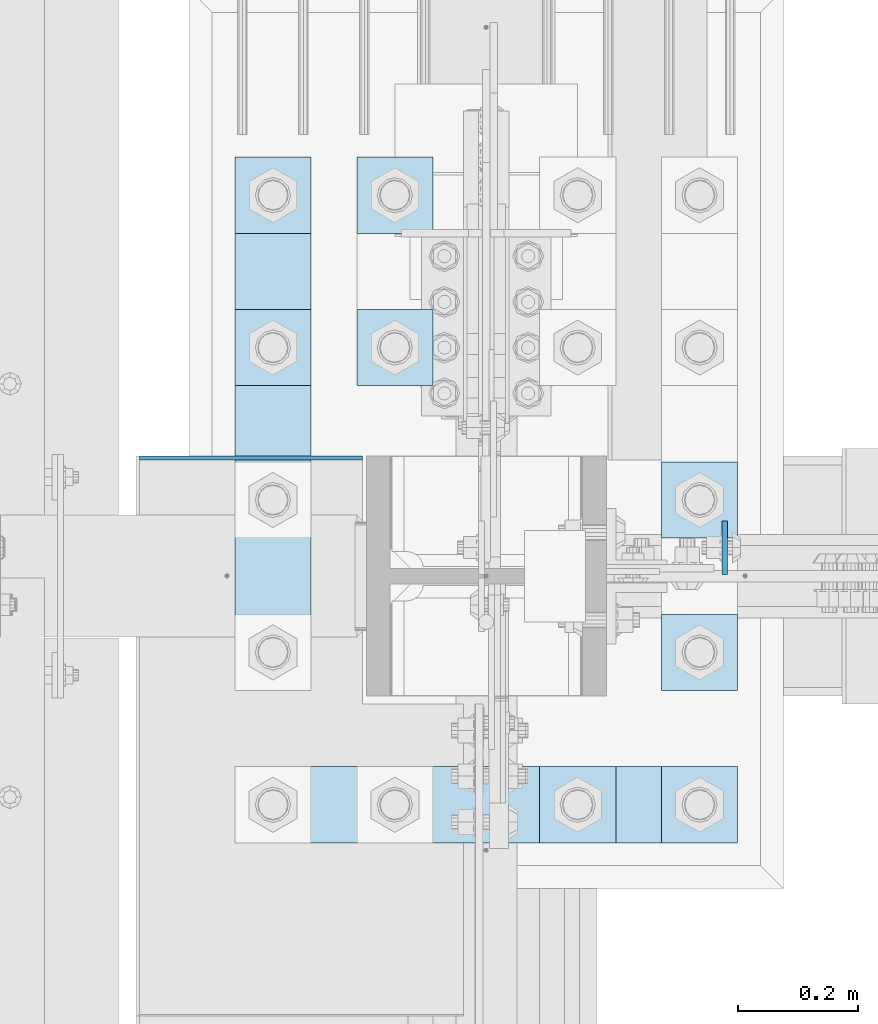
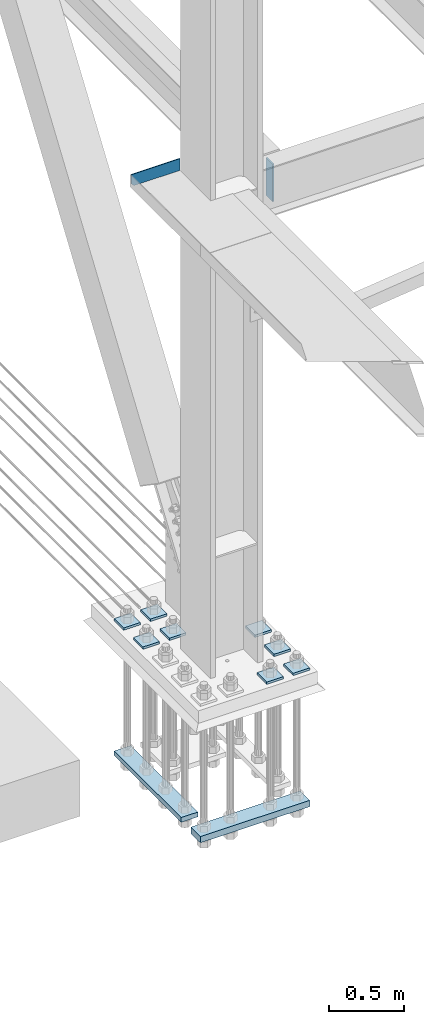
# One storey, part 3250 of 3843: 12 plates, 3 elements without a shape of their own.
"""IFC2X3 building model written with IfcOpenShell, lengths in millimetres."""

from ifc_helpers import new_model, si_unit, frame, origin_with_axes, place, context, subcontext, project, spatial, faceted_brep, material, type_object, element, aggregate, save


model = new_model("IFC2X3")

# Units and contexts
model_context = context("Model", 3, precision=1e-05, world=origin_with_axes())
body_context = subcontext(model_context, "Body", "Model", "MODEL_VIEW")
ifc_project = project(units=[si_unit("LENGTHUNIT", "METRE", prefix="MILLI"), si_unit("AREAUNIT", "SQUARE_METRE"), si_unit("VOLUMEUNIT", "CUBIC_METRE"), si_unit("MASSUNIT", "GRAM", prefix="KILO"), si_unit("TIMEUNIT", "SECOND"), si_unit("PLANEANGLEUNIT", "RADIAN"), si_unit("SOLIDANGLEUNIT", "STERADIAN"), si_unit("THERMODYNAMICTEMPERATUREUNIT", "DEGREE_CELSIUS"), si_unit("LUMINOUSINTENSITYUNIT", "LUMEN")], contexts=[model_context])

# Site, building, storey
site_placement = place(None, origin_with_axes())
site = spatial("IfcSite", under=ifc_project, at=site_placement, CompositionType="ELEMENT")
building_placement = place(site_placement, origin_with_axes())
building = spatial("IfcBuilding", under=site, at=building_placement, Name="Undefined", CompositionType="ELEMENT")
storey_placement = place(building_placement, origin_with_axes())
storey = spatial("IfcBuildingStorey", under=building, at=storey_placement, Name="Undefined", CompositionType="ELEMENT", Elevation=0.0)

# Assembly, plate
assembly_1_placement = place(storey_placement, origin_with_axes())
assembly_1 = element("IfcElementAssembly", 1, at=assembly_1_placement, inside=storey, Name="BEAM", AssemblyPlace="NOTDEFINED", PredefinedType="RIGID_FRAME")
ifc_material = material(Name="STEEL/A572-50")
plate_type_1 = type_object("IfcPlateType", PredefinedType="NOTDEFINED")
plate_1_placement = place(assembly_1_placement, frame((36973.66875, 50561.875, 33997.9), z_axis=(0.0, 1.0, 0.0), x_axis=(0.0, 0.0, -1.0)))
plate_1 = element("IfcPlate", 2, at=plate_1_placement, type_object=plate_type_1, material=ifc_material, Name="PLATE", context=body_context, shape_type="Brep", body=[
    faceted_brep([(0.0, -4.76249999999709, 0.0), (0.0, -4.76249999999709, 88.9000015258789), (0.0, 4.76249999999709, 88.9000015258789), (0.0, 4.76249999999709, 0.0), (304.800000000003, -4.76249999999709, 88.8999999999942), (304.800000000003, 4.76249999999709, 88.8999999999942), (304.800000000003, -4.76249999999709, 0.0), (304.800000000003, 4.76249999999709, 0.0)], [[[0, 1, 2, 3]], [[1, 4, 5, 2]], [[4, 6, 7, 5]], [[6, 0, 3, 7]], [[5, 7, 3, 2]], [[6, 4, 1, 0]]]),
])
aggregate(assembly_1, [plate_1])

assembly_2_placement = place(storey_placement, origin_with_axes())
assembly_2 = element("IfcElementAssembly", 3, at=assembly_2_placement, inside=storey, Name="BEAM", AssemblyPlace="NOTDEFINED", PredefinedType="RIGID_FRAME")
plate_type_2 = type_object("IfcPlateType", PredefinedType="NOTDEFINED")
plate_2_placement = place(assembly_2_placement, frame((35998.1500244141, 50755.55, 34042.35), z_axis=(0.0, 0.0, 1.0), x_axis=(1.0, 0.0, 0.0)))
plate_2 = element("IfcPlate", 4, at=plate_2_placement, type_object=plate_type_2, material=ifc_material, Name="PLATE", context=body_context, shape_type="Brep", body=[
    faceted_brep([(4.36557456851006e-11, -3.17499999998836, 19.0499992370969), (-2.44140610448085e-05, -3.17500000000291, 95.2499999999927), (-2.44140610448085e-05, 3.17500000000291, 95.2499999999927), (1.45519152283669e-11, 3.17499999998836, 19.0499992370824), (371.474975585938, -3.17500000000291, 95.2499999999927), (371.474975585938, 3.17500000000291, 95.2499999999927), (371.474975585938, -3.17500000000291, 0.0), (371.474975585938, 3.17500000000291, 0.0), (19.0499992370023, -3.17500000005384, 0.0), (19.0499992369587, 3.17499999992287, -1.45519152283669e-11)], [[[0, 1, 2, 3]], [[1, 4, 5, 2]], [[4, 6, 7, 5]], [[6, 8, 9, 7]], [[8, 0, 3, 9]], [[5, 7, 9, 3, 2]], [[8, 6, 4, 1, 0]]]),
])
aggregate(assembly_2, [plate_2])

# Assembly, plates
assembly_3_placement = place(storey_placement, origin_with_axes())
assembly_3 = element("IfcElementAssembly", 5, at=assembly_3_placement, inside=storey, Name="TEMPLATE", AssemblyPlace="NOTDEFINED", PredefinedType="RIGID_FRAME")
plate_type_3 = type_object("IfcPlateType", PredefinedType="NOTDEFINED")
plate_3_placement = place(assembly_3_placement, frame((36868.1, 50241.2, 30172.025), z_axis=(0.0, -1.0, 0.0), x_axis=(1.0, 0.0, 0.0)))
plate_3 = element("IfcPlate", 6, at=plate_3_placement, type_object=plate_type_3, material=ifc_material, Name="Washer Plate", context=body_context, shape_type="Brep", body=[
    faceted_brep([(0.0, -9.52500000000146, 0.0), (0.0, -9.52499999999418, 127.0), (0.0, 9.52499999999418, 127.0), (0.0, 9.52500000000146, 0.0), (127.0, -9.52500000000146, 127.0), (127.0, 9.52500000000146, 127.0), (127.0, -9.52500000000146, 0.0), (127.0, 9.52500000000146, 0.0)], [[[0, 1, 2, 3]], [[1, 4, 5, 2]], [[4, 6, 7, 5]], [[6, 0, 3, 7]], [[5, 7, 3, 2]], [[6, 4, 1, 0]]]),
])
plate_4_placement = place(assembly_3_placement, frame((36868.1, 50495.2, 30172.025), z_axis=(0.0, -1.0, 0.0), x_axis=(1.0, 0.0, 0.0)))
plate_4 = element("IfcPlate", 7, at=plate_4_placement, type_object=plate_type_3, material=ifc_material, Name="Washer Plate", context=body_context, shape_type="Brep", body=[
    faceted_brep([(0.0, -9.52500000000146, 0.0), (0.0, -9.52499999999418, 127.0), (0.0, 9.52499999999418, 127.0), (0.0, 9.52500000000146, 0.0), (127.0, -9.52500000000146, 127.0), (127.0, 9.52500000000146, 127.0), (127.0, -9.52500000000146, 0.0), (127.0, 9.52500000000146, 0.0)], [[[0, 1, 2, 3]], [[1, 4, 5, 2]], [[4, 6, 7, 5]], [[6, 0, 3, 7]], [[5, 7, 3, 2]], [[6, 4, 1, 0]]]),
])
plate_5_placement = place(assembly_3_placement, frame((36868.1, 50749.2, 30172.025), z_axis=(0.0, -1.0, 0.0), x_axis=(1.0, 0.0, 0.0)))
plate_5 = element("IfcPlate", 8, at=plate_5_placement, type_object=plate_type_3, material=ifc_material, Name="Washer Plate", context=body_context, shape_type="Brep", body=[
    faceted_brep([(0.0, -9.52500000000146, 0.0), (0.0, -9.52499999999418, 127.0), (0.0, 9.52499999999418, 127.0), (0.0, 9.52500000000146, 0.0), (127.0, -9.52500000000146, 127.0), (127.0, 9.52500000000146, 127.0), (127.0, -9.52500000000146, 0.0), (127.0, 9.52500000000146, 0.0)], [[[0, 1, 2, 3]], [[1, 4, 5, 2]], [[4, 6, 7, 5]], [[6, 0, 3, 7]], [[5, 7, 3, 2]], [[6, 4, 1, 0]]]),
])
plate_6_placement = place(assembly_3_placement, frame((36664.9, 50241.2, 30172.025), z_axis=(0.0, -1.0, 0.0), x_axis=(1.0, 0.0, 0.0)))
plate_6 = element("IfcPlate", 9, at=plate_6_placement, type_object=plate_type_3, material=ifc_material, Name="Washer Plate", context=body_context, shape_type="Brep", body=[
    faceted_brep([(0.0, -9.52500000000146, 0.0), (0.0, -9.52499999999418, 127.0), (0.0, 9.52499999999418, 127.0), (0.0, 9.52500000000146, 0.0), (127.0, -9.52500000000146, 127.0), (127.0, 9.52500000000146, 127.0), (127.0, -9.52500000000146, 0.0), (127.0, 9.52500000000146, 0.0)], [[[0, 1, 2, 3]], [[1, 4, 5, 2]], [[4, 6, 7, 5]], [[6, 0, 3, 7]], [[5, 7, 3, 2]], [[6, 4, 1, 0]]]),
])
plate_7_placement = place(assembly_3_placement, frame((36360.1, 51003.2, 30172.025), z_axis=(0.0, -1.0, 0.0), x_axis=(1.0, 0.0, 0.0)))
plate_7 = element("IfcPlate", 10, at=plate_7_placement, type_object=plate_type_3, material=ifc_material, Name="Washer Plate", context=body_context, shape_type="Brep", body=[
    faceted_brep([(0.0, -9.52500000000146, 0.0), (0.0, -9.52499999999418, 127.0), (0.0, 9.52499999999418, 127.0), (0.0, 9.52500000000146, 0.0), (127.0, -9.52500000000146, 127.0), (127.0, 9.52500000000146, 127.0), (127.0, -9.52500000000146, 0.0), (127.0, 9.52500000000146, 0.0)], [[[0, 1, 2, 3]], [[1, 4, 5, 2]], [[4, 6, 7, 5]], [[6, 0, 3, 7]], [[5, 7, 3, 2]], [[6, 4, 1, 0]]]),
])
plate_8_placement = place(assembly_3_placement, frame((36360.1, 51257.2, 30172.025), z_axis=(0.0, -1.0, 0.0), x_axis=(1.0, 0.0, 0.0)))
plate_8 = element("IfcPlate", 11, at=plate_8_placement, type_object=plate_type_3, material=ifc_material, Name="Washer Plate", context=body_context, shape_type="Brep", body=[
    faceted_brep([(0.0, -9.52500000000146, 0.0), (0.0, -9.52499999999418, 127.0), (0.0, 9.52499999999418, 127.0), (0.0, 9.52500000000146, 0.0), (127.0, -9.52500000000146, 127.0), (127.0, 9.52500000000146, 127.0), (127.0, -9.52500000000146, 0.0), (127.0, 9.52500000000146, 0.0)], [[[0, 1, 2, 3]], [[1, 4, 5, 2]], [[4, 6, 7, 5]], [[6, 0, 3, 7]], [[5, 7, 3, 2]], [[6, 4, 1, 0]]]),
])
plate_9_placement = place(assembly_3_placement, frame((36156.9, 51003.2, 30172.025), z_axis=(0.0, -1.0, 0.0), x_axis=(1.0, 0.0, 0.0)))
plate_9 = element("IfcPlate", 12, at=plate_9_placement, type_object=plate_type_3, material=ifc_material, Name="Washer Plate", context=body_context, shape_type="Brep", body=[
    faceted_brep([(0.0, -9.52500000000146, 0.0), (0.0, -9.52499999999418, 127.0), (0.0, 9.52499999999418, 127.0), (0.0, 9.52500000000146, 0.0), (127.0, -9.52500000000146, 127.0), (127.0, 9.52500000000146, 127.0), (127.0, -9.52500000000146, 0.0), (127.0, 9.52500000000146, 0.0)], [[[0, 1, 2, 3]], [[1, 4, 5, 2]], [[4, 6, 7, 5]], [[6, 0, 3, 7]], [[5, 7, 3, 2]], [[6, 4, 1, 0]]]),
])
plate_10_placement = place(assembly_3_placement, frame((36156.9, 51257.2, 30172.025), z_axis=(0.0, -1.0, 0.0), x_axis=(1.0, 0.0, 0.0)))
plate_10 = element("IfcPlate", 13, at=plate_10_placement, type_object=plate_type_3, material=ifc_material, Name="Washer Plate", context=body_context, shape_type="Brep", body=[
    faceted_brep([(0.0, -9.52500000000146, 0.0), (0.0, -9.52499999999418, 127.0), (0.0, 9.52499999999418, 127.0), (0.0, 9.52500000000146, 0.0), (127.0, -9.52500000000146, 127.0), (127.0, 9.52500000000146, 127.0), (127.0, -9.52500000000146, 0.0), (127.0, 9.52500000000146, 0.0)], [[[0, 1, 2, 3]], [[1, 4, 5, 2]], [[4, 6, 7, 5]], [[6, 0, 3, 7]], [[5, 7, 3, 2]], [[6, 4, 1, 0]]]),
])
plate_type_4 = type_object("IfcPlateType", PredefinedType="NOTDEFINED")
plate_11_placement = place(assembly_3_placement, frame((36156.9, 50368.2, 29089.35), z_axis=(0.0, 1.0, 0.0), x_axis=(1.0, 0.0, 0.0)))
plate_11 = element("IfcPlate", 14, at=plate_11_placement, type_object=plate_type_4, material=ifc_material, Name="PLATE", context=body_context, shape_type="Brep", body=[
    faceted_brep([(0.0, -19.0500000000029, 0.0), (-7.27595761418343e-12, -19.0499999999993, 889.0), (-7.27595761418343e-12, 19.0499999999993, 889.0), (0.0, 19.0500000000029, 0.0), (127.0, -19.0499999999993, 889.0), (127.0, 19.0499999999993, 889.0), (127.0, -19.0499999999993, 0.0), (127.0, 19.0499999999993, 0.0)], [[[0, 1, 2, 3]], [[1, 4, 5, 2]], [[4, 6, 7, 5]], [[6, 0, 3, 7]], [[5, 7, 3, 2]], [[6, 4, 1, 0]]]),
])
plate_type_5 = type_object("IfcPlateType", PredefinedType="NOTDEFINED")
plate_12_placement = place(assembly_3_placement, frame((36995.1, 50114.2, 29083.0), z_axis=(-1.0, 0.0, 0.0), x_axis=(0.0, 1.0, 0.0)))
plate_12 = element("IfcPlate", 15, at=plate_12_placement, type_object=plate_type_5, material=ifc_material, Name="PLATE", context=body_context, shape_type="Brep", body=[
    faceted_brep([(0.0, -25.3999996185303, 0.0), (0.0, -25.4000000000015, 838.200012207031), (0.0, 25.4000000000015, 838.200012207031), (0.0, 25.3999996185303, 0.0), (127.0, -25.4000000000015, 838.200012207031), (127.0, 25.4000000000015, 838.200012207031), (127.0, -25.4000000000015, 0.0), (127.0, 25.4000000000015, 0.0)], [[[0, 1, 2, 3]], [[1, 4, 5, 2]], [[4, 6, 7, 5]], [[6, 0, 3, 7]], [[5, 7, 3, 2]], [[6, 4, 1, 0]]]),
])
aggregate(assembly_3, [plate_11, plate_12, plate_3, plate_4, plate_5, plate_6, plate_7, plate_8, plate_9, plate_10])

save(model, "model.ifc")
